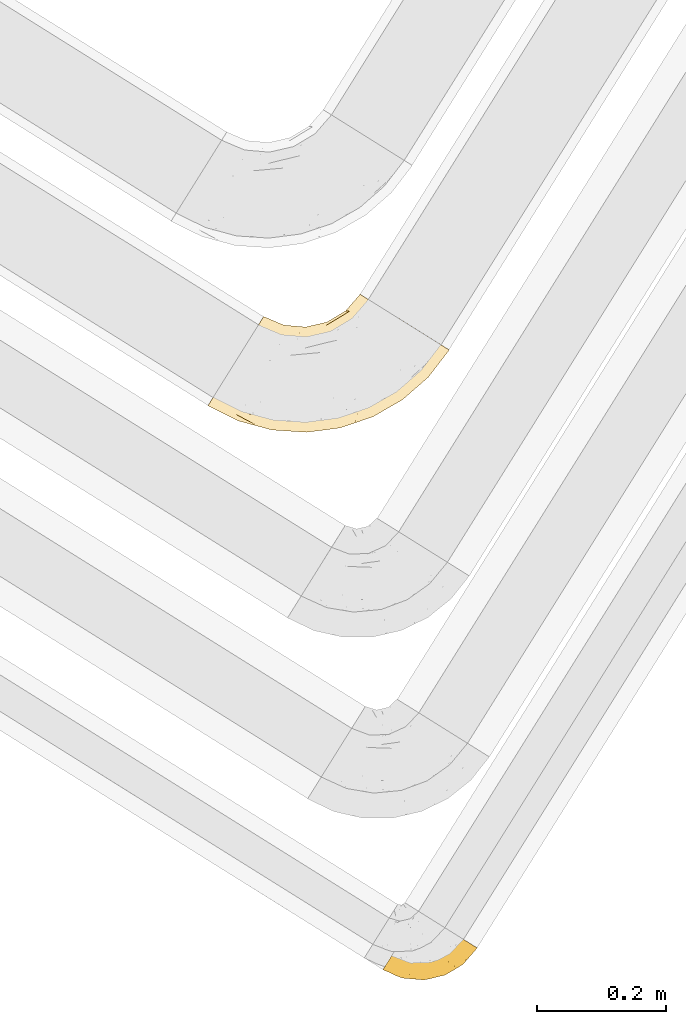
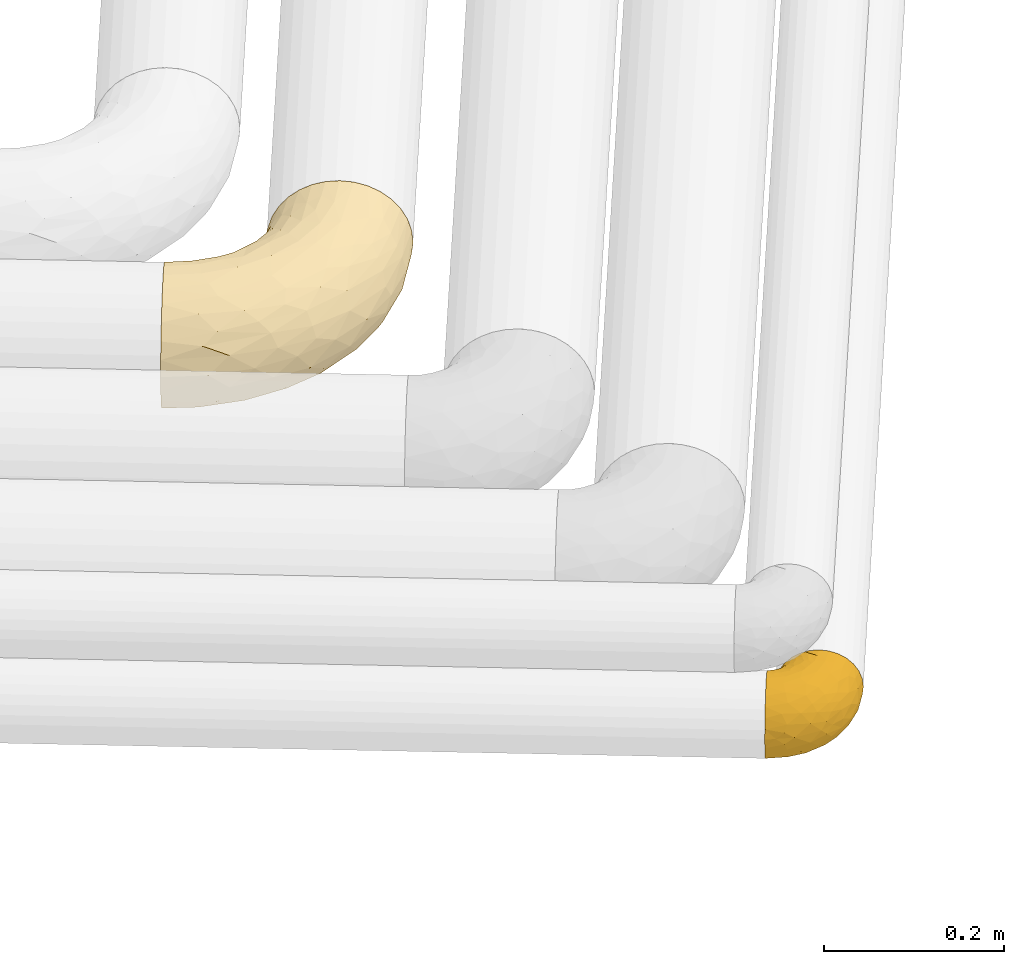
# One storey, part 21 of 93: 2 coverings.
"""IFC2X3 building model written with IfcOpenShell, lengths in millimetres."""

import ifcopenshell
import ifcopenshell.guid

model = None  # the IFC model being written
_history = None  # IfcOwnerHistory: only IFC2X3 demands one
_inside = {}  # id of a spatial element -> (the spatial element, [elements in it])
_under = {}  # id of a project, library or spatial element -> (it, [spatial elements below it])
_declared = {}  # id of a project -> (the project, [libraries it declares])
_typed = {}  # id of a type object -> (the type object, [elements of that type])
_made_of = {}  # id of a material, layer set ... -> (it, [elements and type objects made of it])


def new_model(schema):
    """Start an empty IFC model of exactly this schema.

    Asked for "IFC4X3", IfcOpenShell would pick the latest addendum, in which some entities
    have other attributes; the version numbers below select the first issue.
    IFC2X3 requires an IfcOwnerHistory on every rooted entity: one is made here for all.
    """
    global model, _history
    if schema == "IFC4X3":
        model = ifcopenshell.file(schema_version=(4, 3, 0, 0))
    else:
        model = ifcopenshell.file(schema=schema)
    _inside.clear()
    _under.clear()
    _declared.clear()
    _typed.clear()
    _made_of.clear()
    _history = None
    if model.schema == "IFC2X3":
        org = make("IfcOrganization", Name="unknown")
        user = make(
            "IfcPersonAndOrganization",
            ThePerson=make("IfcPerson", FamilyName="unknown"),
            TheOrganization=org,
        )
        app = make(
            "IfcApplication",
            ApplicationDeveloper=org,
            Version="unknown",
            ApplicationFullName="unknown",
            ApplicationIdentifier="unknown",
        )
        _history = make(
            "IfcOwnerHistory",
            OwningUser=user,
            OwningApplication=app,
            ChangeAction="ADDED",
            CreationDate=0,
        )
    return model


def make(cls, **values):
    """One entity of the class cls with the attributes given. An attribute that is None is left unset."""
    return model.create_entity(
        cls, **{name: value for name, value in values.items() if value is not None}
    )


def entity(cls, *values):
    """Any entity or typed value of the class cls, its attributes in the order of the schema. None: left unset."""
    e = model.create_entity(cls)
    for i, value in enumerate(values):
        if value is not None:
            e[i] = value
    return e


def rooted(cls, **values):
    """An entity with a GlobalId (a new one), such as an element, a storey or a relation."""
    return make(cls, GlobalId=ifcopenshell.guid.new(), OwnerHistory=_history, **values)


def si_unit(unit_type, name, prefix=None):
    """IfcSIUnit, for example si_unit("LENGTHUNIT", "METRE", prefix="MILLI")."""
    return make("IfcSIUnit", UnitType=unit_type, Prefix=prefix, Name=name)


def converted_unit(unit_type, name, factor, base, dimensions=None, offset=None):
    """IfcConversionBasedUnit, such as the inch: factor (a typed value) times the base unit."""
    return make(
        "IfcConversionBasedUnit"
        if offset is None
        else "IfcConversionBasedUnitWithOffset",
        ConversionOffset=offset,
        Dimensions=None
        if dimensions is None
        else entity("IfcDimensionalExponents", *dimensions),
        UnitType=unit_type,
        Name=name,
        ConversionFactor=make(
            "IfcMeasureWithUnit", ValueComponent=factor, UnitComponent=base
        ),
    )


def derived_unit(unit_type, elements):
    """IfcDerivedUnit: a product of units, each with its exponent."""
    return make(
        "IfcDerivedUnit",
        Elements=[
            make("IfcDerivedUnitElement", Unit=unit, Exponent=power)
            for unit, power in elements
        ],
        UnitType=unit_type,
    )


def assignment(units):
    """IfcUnitAssignment: the units of a project."""
    return None if units is None else make("IfcUnitAssignment", Units=units)


def point(xyz):
    """IfcCartesianPoint."""
    return None if xyz is None else make("IfcCartesianPoint", Coordinates=xyz)


def direction(xyz):
    """IfcDirection."""
    return None if xyz is None else make("IfcDirection", DirectionRatios=xyz)


def frame(location, z_axis=None, x_axis=None):
    """IfcAxis2Placement3D, a coordinate frame: its origin and axes. An axis left out is left unset."""
    return make(
        "IfcAxis2Placement3D",
        Location=point(location),
        Axis=direction(z_axis),
        RefDirection=direction(x_axis),
    )


def origin():
    """The frame at (0, 0, 0) with its axes left unset."""
    return frame((0.0, 0.0, 0.0))


def place(relative_to, where):
    """IfcLocalPlacement: puts the frame where relative to a parent placement (None: the world)."""
    return make(
        "IfcLocalPlacement", PlacementRelTo=relative_to, RelativePlacement=where
    )


def context(
    kind, dimensions, precision=None, world=None, true_north=None, identifier=None
):
    """IfcGeometricRepresentationContext, for example the 3D "Model" context."""
    return make(
        "IfcGeometricRepresentationContext",
        ContextIdentifier=identifier,
        ContextType=kind,
        CoordinateSpaceDimension=dimensions,
        Precision=precision,
        WorldCoordinateSystem=world,
        TrueNorth=true_north,
    )


def subcontext(parent, identifier, kind, view, scale=None):
    """IfcGeometricRepresentationSubContext, for example "Body" below "Model"."""
    return make(
        "IfcGeometricRepresentationSubContext",
        ContextIdentifier=identifier,
        ContextType=kind,
        ParentContext=parent,
        TargetScale=scale,
        TargetView=view,
    )


def project(units=None, contexts=None):
    """IfcProject with its units and contexts."""
    return rooted(
        "IfcProject",
        Name="project",
        RepresentationContexts=contexts,
        UnitsInContext=assignment(units),
    )


def spatial(cls, under=None, at=None, **own):
    """A site, building, storey or space (cls), placed at a placement, below another one or the project."""
    s = rooted(cls, ObjectPlacement=at, **own)
    if under is not None:
        _under.setdefault(under.id(), (under, []))[1].append(s)
    return s


def faces_of(points, faces, orient=None, outer=None):
    """IfcFace entities. A face is a list of loops; a loop is a list of indices into points, from 0.

    orient and outer hold one flag for each loop. By default every Orientation is true, the
    first loop of a face is its IfcFaceOuterBound and the others are IfcFaceBound.
    """
    made = []
    for i, loops in enumerate(faces):
        bounds = []
        for j, loop in enumerate(loops):
            is_outer = j == 0 if outer is None else outer[i][j]
            bounds.append(
                make(
                    "IfcFaceOuterBound" if is_outer else "IfcFaceBound",
                    Bound=make("IfcPolyLoop", Polygon=[points[k] for k in loop]),
                    Orientation=True if orient is None else orient[i][j],
                )
            )
        made.append(make("IfcFace", Bounds=bounds))
    return made


def faceted_brep(points, faces, orient=None, outer=None, voids=None):
    """IfcFacetedBrep: a solid bounded by flat faces; with voids (closed shells), ...WithVoids."""
    shared = [point(p) for p in points]
    hull = make("IfcClosedShell", CfsFaces=faces_of(shared, faces, orient, outer))
    if voids is None:
        return make("IfcFacetedBrep", Outer=hull)
    return make(
        "IfcFacetedBrepWithVoids",
        Outer=hull,
        Voids=[
            make(cls, CfsFaces=faces_of(shared, fs, o, b)) for cls, fs, o, b in voids
        ],
    )


def shape(context_of_items, identifier, shape_type, items):
    """IfcShapeRepresentation: the items that make up one representation, for example the "Body"."""
    return make(
        "IfcShapeRepresentation",
        ContextOfItems=context_of_items,
        RepresentationIdentifier=identifier,
        RepresentationType=shape_type,
        Items=items,
    )


def made_of(thing, what):
    """Note that an element or type object is made of a material, layer set ...; save() writes the relation."""
    if what is not None:
        _made_of.setdefault(what.id(), (what, []))[1].append(thing)
    return thing


def element(
    cls,
    number,
    at=None,
    inside=None,
    cuts=None,
    type_object=None,
    material=None,
    context=None,
    identifier="Body",
    shape_type=None,
    held_by="IfcProductDefinitionShape",
    body=None,
    shapes=None,
    **own,
):
    """One element of the class cls, such as IfcWall. Its Tag is "e" and its number.

    at: its placement. inside: the storey or other place that contains it. cuts: it is an
    opening in that element (IfcRelVoidsElement). A single representation is given by context,
    identifier, shape_type and body (its items); several are given by shapes. held_by: the class
    of the entity that holds the representations. save() writes the other relations.
    """
    e = rooted(cls, Tag="e%d" % number, ObjectPlacement=at, **own)
    if body is not None:
        shapes = [shape(context, identifier, shape_type, body)]
    if shapes is not None:
        e.Representation = make(held_by, Representations=shapes)
    if inside is not None:
        _inside.setdefault(inside.id(), (inside, []))[1].append(e)
    if cuts is not None:
        rooted(
            "IfcRelVoidsElement", RelatingBuildingElement=cuts, RelatedOpeningElement=e
        )
    if type_object is not None:
        _typed.setdefault(type_object.id(), (type_object, []))[1].append(e)
    return made_of(e, material)


def aggregate(whole, parts):
    """IfcRelAggregates: a whole, such as a stair, and the parts it consists of."""
    return rooted("IfcRelAggregates", RelatingObject=whole, RelatedObjects=parts)


def save(model, path):
    """Write the relations noted so far, then the file.

    IfcRelAggregates (storeys below a building ...), IfcRelContainedInSpatialStructure (elements
    in a storey), IfcRelDefinesByType, IfcRelAssociatesMaterial and IfcRelDeclares: one each for
    every whole, place, type object, material and project.
    """
    for whole, parts in _under.values():
        aggregate(whole, parts)
    for where, things in _inside.values():
        rooted(
            "IfcRelContainedInSpatialStructure",
            RelatedElements=things,
            RelatingStructure=where,
        )
    for kind, things in _typed.values():
        rooted("IfcRelDefinesByType", RelatedObjects=things, RelatingType=kind)
    for what, things in _made_of.values():
        rooted("IfcRelAssociatesMaterial", RelatedObjects=things, RelatingMaterial=what)
    for by, libraries in _declared.values():
        rooted("IfcRelDeclares", RelatingContext=by, RelatedDefinitions=libraries)
    model.write(path)


model = new_model("IFC2X3")

# Units and contexts
model_context = context("Model", 3, precision=0.01, world=origin(), true_north=direction((6.12303176911189e-17, 1.0)))
body_context = subcontext(model_context, "Body", "Model", "MODEL_VIEW")
ifc_project = project(units=[si_unit("LENGTHUNIT", "METRE", prefix="MILLI"), si_unit("AREAUNIT", "SQUARE_METRE"), si_unit("VOLUMEUNIT", "CUBIC_METRE"), converted_unit("PLANEANGLEUNIT", "DEGREE", entity("IfcRatioMeasure", 0.0174532925199433), si_unit("PLANEANGLEUNIT", "RADIAN"), dimensions=[0, 0, 0, 0, 0, 0, 0]), si_unit("MASSUNIT", "GRAM", prefix="KILO"), derived_unit("MASSDENSITYUNIT", [(si_unit("MASSUNIT", "GRAM", prefix="KILO"), 1), (si_unit("LENGTHUNIT", "METRE"), -3)]), derived_unit("MOMENTOFINERTIAUNIT", [(si_unit("LENGTHUNIT", "METRE"), 4)]), si_unit("TIMEUNIT", "SECOND"), si_unit("FREQUENCYUNIT", "HERTZ"), si_unit("THERMODYNAMICTEMPERATUREUNIT", "DEGREE_CELSIUS"), derived_unit("THERMALTRANSMITTANCEUNIT", [(si_unit("MASSUNIT", "GRAM", prefix="KILO"), 1), (si_unit("THERMODYNAMICTEMPERATUREUNIT", "KELVIN"), -1), (si_unit("TIMEUNIT", "SECOND"), -3)]), derived_unit("VOLUMETRICFLOWRATEUNIT", [(si_unit("LENGTHUNIT", "METRE"), 3), (si_unit("TIMEUNIT", "SECOND"), -1)]), derived_unit("MASSFLOWRATEUNIT", [(si_unit("MASSUNIT", "GRAM", prefix="KILO"), 1), (si_unit("TIMEUNIT", "SECOND"), -1)]), derived_unit("ROTATIONALFREQUENCYUNIT", [(si_unit("TIMEUNIT", "SECOND"), -1)]), si_unit("ELECTRICCURRENTUNIT", "AMPERE"), si_unit("ELECTRICVOLTAGEUNIT", "VOLT"), si_unit("POWERUNIT", "WATT"), si_unit("FORCEUNIT", "NEWTON", prefix="KILO"), si_unit("ILLUMINANCEUNIT", "LUX"), si_unit("LUMINOUSFLUXUNIT", "LUMEN"), si_unit("LUMINOUSINTENSITYUNIT", "CANDELA"), derived_unit("USERDEFINED", [(si_unit("MASSUNIT", "GRAM", prefix="KILO"), -1), (si_unit("LENGTHUNIT", "METRE"), -2), (si_unit("TIMEUNIT", "SECOND"), 3), (si_unit("LUMINOUSFLUXUNIT", "LUMEN"), 1)]), derived_unit("LINEARVELOCITYUNIT", [(si_unit("LENGTHUNIT", "METRE"), 1), (si_unit("TIMEUNIT", "SECOND"), -1)]), si_unit("PRESSUREUNIT", "PASCAL"), derived_unit("USERDEFINED", [(si_unit("LENGTHUNIT", "METRE"), -2), (si_unit("MASSUNIT", "GRAM", prefix="KILO"), 1), (si_unit("TIMEUNIT", "SECOND"), -2)]), derived_unit("LINEARFORCEUNIT", [(si_unit("MASSUNIT", "GRAM", prefix="KILO"), 1), (si_unit("LENGTHUNIT", "METRE"), 1), (si_unit("TIMEUNIT", "SECOND"), -2), (si_unit("LENGTHUNIT", "METRE"), -1)]), derived_unit("PLANARFORCEUNIT", [(si_unit("MASSUNIT", "GRAM", prefix="KILO"), 1), (si_unit("LENGTHUNIT", "METRE"), 1), (si_unit("TIMEUNIT", "SECOND"), -2), (si_unit("LENGTHUNIT", "METRE"), -2)])], contexts=[model_context])

# Site, building, storey
site_placement = place(None, origin())
site = spatial("IfcSite", under=ifc_project, at=site_placement, CompositionType="ELEMENT")
building_placement = place(site_placement, origin())
building = spatial("IfcBuilding", under=site, at=building_placement, CompositionType="ELEMENT")
storey_placement = place(building_placement, frame((0.0, 0.0, -4200.0)))
storey = spatial("IfcBuildingStorey", under=building, at=storey_placement, CompositionType="ELEMENT", Elevation=-4200.0)

# Coverings
covering_1_placement = place(storey_placement, frame((13072.91, 7155.01, 2916.9)))
element("IfcCovering", 1, at=covering_1_placement, inside=storey, Name=":ADSK_", ObjectType=":ADSK_", PredefinedType="INSULATION", context=body_context, shape_type="Brep", body=[
    faceted_brep([(333.05, 155.76, 158.39), (345.0, 148.29, 150.86), (355.47, 141.74, 140.72), (364.07, 136.37, 128.37), (370.45, 132.38, 114.28), (374.39, 129.93, 98.99), (375.71, 129.1, 83.1), (374.39, 129.93, 67.2), (370.45, 132.38, 51.91), (364.07, 136.37, 37.82), (355.47, 141.75, 25.47), (345.0, 148.29, 15.33), (333.05, 155.76, 7.8), (320.08, 163.86, 3.16), (306.6, 172.28, 1.6), (293.11, 180.71, 3.16), (280.15, 188.81, 7.8), (268.2, 196.28, 15.33), (257.72, 202.82, 25.47), (249.13, 208.19, 37.82), (242.74, 212.19, 51.91), (238.81, 214.64, 67.2), (237.48, 215.47, 83.1), (238.81, 214.64, 99.0), (242.74, 212.18, 114.28), (249.13, 208.19, 128.37), (257.73, 202.82, 140.72), (268.2, 196.28, 150.86), (280.15, 188.81, 158.39), (293.11, 180.71, 163.03), (306.6, 172.28, 164.6), (320.08, 163.86, 163.03), (86.5, 178.6, 62.0), (82.19, 171.7, 42.35), (75.32, 160.71, 25.47), (66.38, 146.4, 12.51), (55.96, 129.73, 4.37), (44.78, 111.84, 1.6), (33.61, 93.95, 4.37), (23.19, 77.28, 12.51), (14.24, 62.97, 25.47), (7.38, 51.98, 42.35), (3.07, 45.08, 62.0), (1.6, 42.72, 83.1), (3.07, 45.08, 104.19), (7.38, 51.98, 123.85), (14.24, 62.97, 140.72), (23.19, 77.28, 153.68), (33.61, 93.95, 161.82), (44.78, 111.84, 164.6), (55.96, 129.73, 161.82), (66.38, 146.4, 153.68), (75.32, 160.71, 140.72), (82.19, 171.7, 123.85), (86.5, 178.6, 104.19), (87.97, 180.96, 83.1), (73.32, 14.25, 104.67), (49.28, 19.08, 83.1), (100.66, 5.19, 83.1), (114.71, 20.18, 132.71), (174.6, 16.99, 128.57), (151.43, 25.0, 140.31), (233.45, 29.73, 127.0), (177.21, 8.64, 111.93), (231.49, 19.35, 107.33), (179.96, 4.78, 96.47), (307.55, 107.43, 153.13), (124.77, 10.77, 119.3), (130.28, 3.96, 101.32), (248.47, 50.29, 142.92), (292.17, 75.9, 142.61), (267.0, 73.32, 151.87), (82.36, 74.66, 162.56), (124.67, 84.11, 164.6), (83.16, 93.47, 164.6), (153.76, 1.6, 83.1), (294.51, 55.47, 117.97), (330.51, 86.29, 119.64), (292.72, 63.77, 131.15), (206.54, 8.43, 83.1), (256.98, 25.43, 83.1), (83.34, 56.33, 156.52), (103.14, 32.76, 144.21), (53.94, 49.47, 146.25), (66.06, 29.24, 130.43), (280.15, 138.95, 164.6), (268.66, 104.99, 162.51), (152.45, 56.01, 159.97), (160.3, 38.77, 151.26), (218.74, 49.94, 151.21), (47.82, 27.91, 117.68), (235.35, 70.49, 158.25), (225.16, 83.18, 163.04), (334.96, 82.83, 105.24), (293.47, 47.68, 100.78), (326.56, 110.08, 144.52), (200.91, 32.82, 141.87), (327.62, 95.07, 132.77), (303.13, 51.94, 83.1), (343.22, 86.94, 83.1), (246.96, 112.34, 164.6), (208.67, 93.79, 164.6), (167.21, 84.22, 164.6), (96.56, 136.17, 151.23), (115.61, 146.97, 137.69), (92.84, 114.26, 161.34), (212.5, 158.19, 141.27), (235.38, 178.47, 138.72), (213.32, 172.34, 127.05), (183.93, 166.75, 109.71), (215.21, 189.85, 83.1), (186.11, 172.37, 83.1), (141.85, 155.47, 120.43), (152.86, 142.71, 138.75), (180.6, 155.3, 129.2), (208.22, 115.77, 161.91), (232.67, 129.94, 161.43), (208.21, 132.86, 155.97), (141.4, 101.07, 162.57), (182.16, 114.05, 160.03), (161.3, 127.64, 151.82), (109.57, 162.72, 117.14), (221.04, 189.1, 109.48), (251.07, 178.12, 148.92), (233.51, 156.04, 151.93), (129.93, 122.41, 154.85), (109.87, 168.83, 98.92), (136.86, 162.82, 100.98), (153.04, 164.73, 83.1), (119.22, 167.69, 83.1), (187.72, 142.04, 145.5), (257.98, 161.65, 158.16), (255.6, 138.49, 162.97), (275.48, 159.5, 162.71), (163.68, 164.47, 98.76), (117.12, 112.0, 160.15), (232.57, 191.04, 124.12), (185.16, 128.4, 154.06), (129.93, 122.41, 11.34), (115.61, 146.97, 28.5), (152.86, 142.71, 27.44), (161.3, 127.64, 14.37), (109.87, 168.83, 67.27), (136.86, 162.82, 65.22), (213.32, 172.34, 39.14), (212.5, 158.19, 24.93), (180.59, 155.3, 36.99), (275.48, 159.5, 3.48), (183.93, 166.75, 56.48), (96.56, 136.17, 14.96), (92.84, 114.26, 4.85), (232.57, 191.04, 42.07), (235.37, 178.47, 27.47), (141.85, 155.47, 45.76), (163.68, 164.47, 67.43), (255.6, 138.49, 3.22), (257.97, 161.65, 8.03), (83.16, 93.47, 1.6), (109.57, 162.72, 49.05), (251.06, 178.12, 17.27), (221.04, 189.1, 56.71), (116.64, 100.86, 3.08), (141.4, 101.07, 3.62), (246.96, 112.34, 1.6), (208.67, 93.79, 1.6), (232.67, 129.94, 4.76), (167.21, 84.22, 1.6), (124.67, 84.11, 1.6), (187.72, 142.04, 20.69), (182.16, 114.05, 6.16), (233.51, 156.04, 14.26), (208.21, 132.86, 10.22), (208.22, 115.77, 4.28), (280.15, 138.95, 1.6), (185.27, 128.83, 12.35), (66.06, 29.24, 35.76), (292.17, 75.9, 23.58), (292.75, 63.8, 35.03), (252.21, 41.3, 34.03), (341.92, 98.49, 46.35), (108.38, 67.99, 3.68), (157.04, 67.45, 3.15), (153.44, 51.58, 7.94), (200.91, 32.82, 24.32), (196.81, 18.01, 41.48), (234.3, 74.91, 6.22), (267.73, 108.91, 2.91), (173.65, 7.09, 57.48), (95.34, 51.66, 10.43), (109.73, 21.2, 33.0), (103.14, 32.76, 21.98), (150.87, 22.88, 28.1), (80.4, 17.62, 47.91), (326.56, 110.08, 21.67), (231.49, 19.35, 58.86), (300.52, 98.91, 13.93), (124.77, 10.77, 46.89), (124.71, 4.81, 62.93), (53.94, 49.47, 19.94), (73.32, 14.25, 61.52), (250.33, 62.77, 15.08), (289.86, 109.21, 6.68), (293.47, 47.68, 65.41), (158.95, 36.16, 16.65), (202.31, 51.14, 11.53), (334.96, 82.83, 60.95), (327.61, 95.07, 33.42), (294.51, 55.47, 48.22)], [[[0, 1, 2, 3, 4, 5, 6, 7, 8, 9, 10, 11, 12, 13, 14, 15, 16, 17, 18, 19, 20, 21, 22, 23, 24, 25, 26, 27, 28, 29, 30, 31]], [[32, 33, 34, 35, 36, 37, 38, 39, 40, 41, 42, 43, 44, 45, 46, 47, 48, 49, 50, 51, 52, 53, 54, 55]], [[56, 57, 58]], [[57, 44, 43]], [[59, 60, 61]], [[62, 63, 64]], [[63, 65, 64]], [[1, 0, 66]], [[67, 68, 63]], [[69, 70, 71]], [[72, 73, 74]], [[75, 68, 58]], [[76, 77, 78]], [[64, 79, 80]], [[81, 48, 47]], [[82, 83, 84]], [[31, 85, 86]], [[71, 70, 66]], [[47, 83, 81]], [[87, 88, 89]], [[69, 62, 78]], [[49, 48, 72]], [[90, 44, 56]], [[48, 81, 72]], [[87, 91, 92]], [[93, 76, 94]], [[70, 95, 66]], [[88, 96, 89]], [[45, 84, 46]], [[2, 95, 97]], [[4, 93, 5]], [[98, 99, 93]], [[59, 84, 67]], [[3, 97, 77]], [[71, 86, 91]], [[4, 3, 77]], [[90, 84, 45]], [[99, 6, 5]], [[83, 47, 46]], [[95, 2, 1]], [[94, 80, 98]], [[100, 101, 92]], [[66, 31, 86]], [[60, 63, 62]], [[85, 31, 30]], [[102, 87, 92]], [[93, 77, 76]], [[91, 86, 92]], [[44, 57, 56]], [[86, 85, 100]], [[78, 97, 70]], [[87, 102, 73]], [[2, 97, 3]], [[67, 84, 90]], [[31, 66, 0]], [[93, 94, 98]], [[88, 81, 82]], [[99, 5, 93]], [[87, 73, 72]], [[66, 95, 1]], [[97, 95, 70]], [[86, 71, 66]], [[69, 89, 96]], [[89, 71, 91]], [[69, 96, 62]], [[60, 62, 96]], [[76, 62, 64]], [[71, 89, 69]], [[87, 89, 91]], [[81, 88, 87]], [[61, 88, 82]], [[61, 60, 96]], [[60, 67, 63]], [[68, 67, 56]], [[79, 65, 75]], [[58, 68, 56]], [[65, 68, 75]], [[64, 65, 79]], [[68, 65, 63]], [[76, 64, 94]], [[80, 94, 64]], [[100, 92, 86]], [[92, 101, 102]], [[88, 61, 96]], [[59, 61, 82]], [[84, 59, 82]], [[60, 59, 67]], [[87, 72, 81]], [[49, 72, 74]], [[84, 83, 46]], [[81, 83, 82]], [[69, 78, 70]], [[62, 76, 78]], [[4, 77, 93]], [[78, 77, 97]], [[44, 90, 45]], [[67, 90, 56]], [[103, 104, 52]], [[50, 49, 74]], [[50, 74, 105]], [[106, 107, 108]], [[109, 110, 111]], [[112, 113, 114]], [[104, 113, 112]], [[73, 105, 74]], [[115, 116, 117]], [[118, 119, 120]], [[104, 53, 52]], [[51, 103, 52]], [[53, 121, 54]], [[24, 23, 122]], [[123, 107, 124]], [[122, 109, 108]], [[125, 120, 113]], [[55, 54, 126]], [[102, 118, 73]], [[127, 126, 121]], [[128, 129, 127]], [[105, 51, 50]], [[102, 101, 119]], [[120, 130, 113]], [[26, 123, 27]], [[27, 131, 28]], [[132, 85, 133]], [[85, 29, 133]], [[134, 111, 128]], [[28, 133, 29]], [[30, 29, 85]], [[116, 131, 124]], [[135, 73, 118]], [[27, 123, 131]], [[110, 23, 22]], [[136, 122, 108]], [[24, 136, 25]], [[114, 108, 109]], [[119, 115, 117]], [[136, 107, 25]], [[128, 127, 134]], [[122, 110, 109]], [[104, 112, 121]], [[107, 106, 124]], [[107, 26, 25]], [[23, 110, 122]], [[101, 100, 116]], [[131, 132, 133]], [[105, 135, 103]], [[116, 124, 117]], [[122, 136, 24]], [[107, 136, 108]], [[28, 131, 133]], [[131, 116, 132]], [[126, 127, 129]], [[134, 112, 109]], [[107, 123, 26]], [[131, 123, 124]], [[104, 121, 53]], [[127, 121, 112]], [[105, 103, 51]], [[104, 103, 125]], [[116, 100, 132]], [[85, 132, 100]], [[106, 117, 124]], [[137, 130, 120]], [[114, 106, 108]], [[106, 130, 117]], [[119, 118, 102]], [[135, 118, 125]], [[125, 113, 104]], [[114, 113, 130]], [[114, 130, 106]], [[112, 114, 109]], [[118, 120, 125]], [[117, 137, 119]], [[55, 126, 129]], [[121, 126, 54]], [[112, 134, 127]], [[111, 134, 109]], [[119, 101, 115]], [[101, 116, 115]], [[103, 135, 125]], [[73, 135, 105]], [[130, 137, 117]], [[120, 119, 137]], [[138, 139, 140]], [[140, 141, 138]], [[55, 129, 142]], [[143, 142, 129]], [[144, 145, 146]], [[147, 16, 15]], [[110, 148, 111]], [[128, 143, 129]], [[149, 150, 35]], [[151, 152, 144]], [[153, 143, 154]], [[147, 155, 156]], [[35, 150, 36]], [[37, 36, 157]], [[35, 34, 149]], [[139, 33, 158]], [[159, 152, 18]], [[150, 157, 36]], [[140, 139, 153]], [[139, 34, 33]], [[110, 21, 160]], [[150, 161, 157]], [[20, 19, 151]], [[161, 138, 162]], [[110, 22, 21]], [[163, 164, 165]], [[166, 167, 162]], [[151, 160, 20]], [[140, 146, 168]], [[111, 148, 154]], [[164, 166, 169]], [[18, 152, 19]], [[170, 156, 165]], [[17, 159, 18]], [[158, 33, 32]], [[171, 165, 172]], [[155, 165, 156]], [[148, 110, 160]], [[170, 159, 156]], [[160, 144, 148]], [[15, 14, 173]], [[170, 171, 145]], [[149, 139, 138]], [[15, 173, 147]], [[144, 152, 145]], [[156, 17, 16]], [[165, 171, 170]], [[20, 160, 21]], [[171, 172, 169]], [[169, 166, 162]], [[152, 151, 19]], [[160, 151, 144]], [[155, 173, 163]], [[156, 16, 147]], [[154, 143, 128]], [[143, 153, 158]], [[156, 159, 17]], [[152, 159, 170]], [[158, 32, 142]], [[139, 158, 153]], [[139, 149, 34]], [[150, 149, 138]], [[173, 155, 147]], [[163, 165, 155]], [[174, 169, 141]], [[145, 171, 168]], [[170, 145, 152]], [[146, 145, 168]], [[161, 162, 167]], [[162, 138, 141]], [[146, 153, 148]], [[140, 168, 141]], [[153, 146, 140]], [[144, 146, 148]], [[174, 141, 168]], [[162, 141, 169]], [[158, 142, 143]], [[55, 142, 32]], [[111, 154, 128]], [[153, 154, 148]], [[165, 164, 172]], [[164, 169, 172]], [[157, 161, 167]], [[138, 161, 150]], [[168, 171, 174]], [[169, 174, 171]], [[41, 40, 175]], [[176, 177, 178]], [[9, 8, 179]], [[180, 181, 182]], [[157, 180, 37]], [[183, 178, 184]], [[164, 185, 181]], [[13, 186, 173]], [[187, 79, 75]], [[167, 166, 181]], [[186, 163, 173]], [[182, 188, 180]], [[57, 43, 42]], [[189, 190, 191]], [[164, 186, 185]], [[192, 41, 175]], [[193, 11, 10]], [[178, 194, 184]], [[12, 11, 195]], [[196, 187, 197]], [[40, 198, 175]], [[198, 40, 39]], [[58, 199, 197]], [[200, 185, 201]], [[163, 186, 164]], [[201, 185, 186]], [[202, 80, 194]], [[190, 203, 191]], [[201, 186, 13]], [[204, 185, 200]], [[201, 13, 12]], [[41, 199, 42]], [[195, 200, 201]], [[98, 205, 99]], [[57, 42, 199]], [[13, 173, 14]], [[58, 57, 199]], [[193, 206, 176]], [[80, 79, 194]], [[207, 205, 202]], [[196, 184, 187]], [[202, 205, 98]], [[205, 179, 8]], [[9, 206, 10]], [[207, 206, 179]], [[182, 203, 188]], [[6, 99, 7]], [[188, 38, 180]], [[203, 182, 204]], [[7, 205, 8]], [[37, 180, 38]], [[167, 180, 157]], [[7, 99, 205]], [[182, 181, 185]], [[11, 193, 195]], [[196, 191, 184]], [[175, 189, 192]], [[198, 188, 190]], [[38, 188, 39]], [[206, 193, 10]], [[195, 193, 176]], [[195, 176, 200]], [[12, 195, 201]], [[178, 200, 176]], [[185, 204, 182]], [[200, 183, 204]], [[203, 204, 183]], [[191, 203, 183]], [[188, 203, 190]], [[184, 191, 183]], [[190, 189, 175]], [[200, 178, 183]], [[184, 194, 187]], [[177, 176, 206]], [[194, 178, 207]], [[79, 187, 194]], [[197, 199, 192]], [[187, 75, 197]], [[58, 197, 75]], [[191, 196, 189]], [[192, 189, 196]], [[80, 202, 98]], [[194, 207, 202]], [[167, 181, 180]], [[181, 166, 164]], [[188, 198, 39]], [[175, 198, 190]], [[207, 179, 205]], [[9, 179, 206]], [[197, 192, 196]], [[41, 192, 199]], [[206, 207, 177]], [[207, 178, 177]]]),
])
covering_2_placement = place(storey_placement, frame((13344.15, 6306.06, 2892.1)))
element("IfcCovering", 2, at=covering_2_placement, inside=storey, Name=":ADSK_", ObjectType=":ADSK_", PredefinedType="INSULATION", context=body_context, shape_type="Brep", body=[
    faceted_brep([(106.18, 77.28, 99.9), (115.46, 71.48, 98.66), (124.28, 65.98, 95.02), (132.18, 61.04, 89.17), (138.78, 56.92, 81.38), (143.74, 53.81, 72.06), (146.82, 51.89, 61.68), (147.87, 51.24, 50.75), (146.82, 51.89, 39.8), (143.74, 53.82, 29.41), (138.77, 56.92, 20.09), (132.17, 61.05, 12.31), (124.26, 65.98, 6.46), (115.45, 71.49, 2.83), (106.18, 77.28, 1.6), (101.35, 80.3, 2.24), (96.91, 83.08, 2.83), (92.5, 85.83, 4.65), (88.09, 88.59, 6.47), (80.19, 93.52, 12.32), (73.59, 97.65, 20.11), (68.63, 100.75, 29.43), (65.55, 102.67, 39.81), (64.5, 103.33, 50.75), (65.55, 102.67, 61.69), (68.63, 100.75, 72.08), (73.6, 97.64, 81.4), (80.2, 93.52, 89.18), (88.11, 88.58, 95.03), (92.51, 85.83, 96.85), (96.92, 83.07, 98.66), (101.35, 80.3, 99.25), (103.77, 78.79, 99.57), (52.8, 99.41, 38.02), (50.2, 95.25, 26.17), (48.13, 91.93, 21.08), (46.06, 88.62, 15.99), (43.36, 84.31, 12.09), (40.66, 79.99, 8.18), (37.52, 74.96, 5.73), (34.38, 69.94, 3.27), (30.68, 64.01, 2.35), (29.16, 61.58, 1.97), (27.64, 59.15, 1.6), (20.9, 48.36, 3.27), (14.62, 38.31, 8.18), (9.22, 29.67, 15.99), (5.08, 23.05, 26.17), (2.48, 18.89, 38.02), (1.6, 17.47, 50.75), (2.48, 18.89, 63.47), (5.08, 23.05, 75.32), (9.22, 29.67, 85.5), (14.62, 38.31, 93.31), (20.9, 48.36, 98.22), (27.64, 59.15, 99.9), (30.68, 64.01, 99.14), (34.38, 69.94, 98.22), (37.52, 74.96, 95.77), (40.66, 79.99, 93.31), (43.36, 84.31, 89.4), (46.06, 88.62, 85.5), (48.13, 91.93, 80.41), (50.2, 95.25, 75.32), (52.8, 99.41, 63.47), (53.69, 100.83, 50.75), (73.31, 3.23, 59.31), (63.34, 6.85, 73.08), (52.09, 3.24, 63.72), (32.17, 4.49, 50.75), (21.61, 8.39, 58.64), (12.86, 12.69, 50.75), (43.87, 9.77, 76.74), (25.69, 9.49, 67.68), (23.01, 16.67, 78.92), (98.3, 38.75, 94.31), (101.46, 55.97, 98.76), (83.87, 43.54, 98.4), (36.32, 31.21, 94.57), (56.63, 20.8, 89.91), (63.92, 32.34, 96.32), (40.28, 42.43, 98.79), (48.44, 51.27, 99.9), (43.21, 53.25, 99.9), (37.98, 55.23, 99.9), (35.39, 56.21, 99.9), (32.81, 57.19, 99.9), (33.49, 21.01, 87.31), (112.0, 52.64, 95.61), (112.46, 17.59, 60.43), (130.36, 32.99, 65.24), (112.5, 22.68, 72.87), (90.95, 61.08, 99.9), (85.88, 58.8, 99.9), (80.81, 56.51, 99.9), (75.74, 54.23, 99.9), (70.67, 51.95, 99.9), (118.64, 47.08, 90.65), (96.67, 10.4, 63.14), (74.9, 25.36, 91.89), (131.15, 40.05, 75.25), (139.84, 42.0, 50.75), (59.94, 12.73, 82.18), (78.9, 17.76, 85.08), (80.37, 11.5, 76.93), (97.61, 9.07, 50.75), (81.43, 5.33, 50.75), (121.38, 38.11, 83.02), (104.29, 75.27, 99.9), (102.4, 73.26, 99.9), (98.61, 69.23, 99.9), (94.78, 65.16, 99.9), (103.3, 29.76, 87.13), (95.69, 19.42, 80.85), (61.66, 42.17, 99.17), (126.08, 26.17, 50.75), (65.11, 51.78, 99.9), (59.55, 51.61, 99.9), (54.0, 51.44, 99.9), (65.25, 1.6, 50.75), (81.05, 6.96, 67.61), (96.0, 13.76, 72.25), (111.84, 17.62, 50.75), (48.71, 3.04, 50.75), (91.72, 76.09, 98.69), (38.92, 63.66, 99.01), (48.91, 61.7, 98.79), (43.4, 65.35, 98.29), (64.06, 98.2, 68.51), (66.59, 94.88, 76.82), (81.93, 68.86, 98.54), (86.96, 67.63, 99.3), (52.94, 87.67, 83.57), (50.78, 81.71, 89.47), (56.25, 92.88, 75.76), (58.26, 85.87, 84.86), (62.6, 93.51, 75.89), (58.48, 97.61, 64.77), (66.65, 80.31, 90.83), (71.97, 75.63, 94.62), (72.35, 83.63, 90.37), (47.07, 80.5, 91.18), (75.48, 88.78, 88.65), (69.69, 90.26, 84.11), (61.83, 77.85, 91.75), (85.19, 78.29, 96.86), (59.61, 99.84, 50.75), (62.39, 100.25, 58.97), (76.09, 66.51, 98.37), (65.46, 88.2, 83.91), (68.03, 66.83, 97.52), (48.73, 71.84, 95.55), (54.08, 61.15, 98.76), (54.18, 71.52, 95.26), (61.38, 64.0, 98.04), (56.26, 79.22, 90.65), (80.2, 83.52, 93.51), (76.45, 79.07, 94.16), (58.74, 59.29, 99.1), (56.24, 92.88, 25.73), (56.25, 79.23, 10.84), (52.93, 87.67, 17.92), (58.24, 85.89, 16.64), (65.43, 97.88, 30.44), (81.93, 68.85, 2.95), (86.96, 67.64, 2.19), (85.88, 58.8, 1.6), (85.18, 78.3, 4.63), (69.68, 90.26, 17.39), (30.22, 58.17, 1.6), (37.98, 55.23, 1.6), (32.81, 57.19, 1.6), (75.45, 88.78, 12.86), (72.33, 83.63, 11.13), (43.4, 65.35, 3.2), (48.73, 71.84, 5.94), (50.78, 81.7, 12.02), (54.18, 71.52, 6.23), (47.07, 80.5, 10.31), (80.17, 83.55, 8.0), (76.44, 79.08, 7.34), (38.92, 63.66, 2.48), (54.08, 61.15, 2.73), (48.97, 61.41, 2.64), (98.61, 69.23, 1.6), (91.71, 76.09, 2.8), (58.47, 97.61, 36.71), (43.21, 53.25, 1.6), (48.44, 51.27, 1.6), (62.49, 99.34, 38.59), (102.4, 73.26, 1.6), (100.51, 71.24, 1.6), (80.81, 56.51, 1.6), (76.09, 66.51, 3.12), (65.44, 88.21, 17.59), (75.74, 54.23, 1.6), (68.0, 66.86, 3.98), (71.96, 75.62, 6.87), (61.38, 64.01, 3.45), (61.81, 77.88, 9.76), (94.78, 65.16, 1.6), (90.95, 61.08, 1.6), (62.6, 93.51, 25.62), (66.64, 80.32, 10.67), (58.74, 59.29, 2.39), (59.55, 51.61, 1.6), (54.0, 51.44, 1.6), (65.11, 51.78, 1.6), (70.67, 51.95, 1.6), (61.75, 41.76, 2.4), (21.61, 8.39, 42.85), (33.49, 21.01, 14.18), (56.28, 20.84, 11.56), (59.9, 12.76, 19.27), (43.88, 9.76, 24.75), (63.39, 6.88, 28.37), (112.3, 52.74, 5.95), (101.55, 55.68, 2.79), (40.28, 42.43, 2.71), (52.09, 3.24, 37.78), (25.69, 9.49, 33.81), (23.02, 16.67, 22.57), (36.32, 31.21, 6.92), (112.5, 22.69, 28.61), (130.36, 32.99, 36.24), (112.45, 17.59, 41.05), (80.47, 11.53, 24.55), (81.05, 6.96, 33.88), (98.8, 39.2, 7.11), (73.31, 3.23, 42.18), (121.37, 38.11, 18.46), (118.63, 47.09, 10.84), (95.81, 19.43, 20.69), (96.03, 13.75, 29.27), (83.87, 43.5, 3.1), (81.13, 27.58, 9.18), (96.63, 10.38, 38.38), (131.14, 40.05, 26.23), (103.13, 29.68, 14.34), (64.07, 31.65, 5.46), (78.9, 17.77, 16.39)], [[[0, 1, 2, 3, 4, 5, 6, 7, 8, 9, 10, 11, 12, 13, 14, 15, 16, 17, 18, 19, 20, 21, 22, 23, 24, 25, 26, 27, 28, 29, 30, 31, 32]], [[33, 34, 35, 36, 37, 38, 39, 40, 41, 42, 43, 44, 45, 46, 47, 48, 49, 50, 51, 52, 53, 54, 55, 56, 57, 58, 59, 60, 61, 62, 63, 64, 65]], [[66, 67, 68]], [[69, 70, 71]], [[68, 72, 73]], [[73, 72, 74]], [[75, 76, 77]], [[78, 79, 80]], [[51, 50, 73]], [[81, 82, 83, 84, 85, 86, 55]], [[52, 87, 53]], [[74, 52, 51]], [[2, 1, 88]], [[89, 90, 91]], [[77, 92, 93, 94, 95, 96]], [[55, 54, 81]], [[78, 53, 87]], [[5, 90, 6]], [[88, 76, 75]], [[97, 3, 2]], [[89, 91, 98]], [[99, 80, 79]], [[90, 5, 100]], [[74, 87, 52]], [[100, 5, 4]], [[90, 101, 6]], [[79, 102, 103]], [[102, 67, 104]], [[105, 98, 106]], [[107, 4, 3]], [[76, 0, 108, 109, 110, 111, 92]], [[107, 112, 113]], [[114, 77, 96]], [[89, 115, 90]], [[114, 96, 116, 117, 118, 82]], [[75, 97, 88]], [[119, 66, 68]], [[50, 71, 70]], [[100, 91, 90]], [[99, 77, 80]], [[102, 104, 103]], [[97, 107, 3]], [[80, 81, 78]], [[107, 97, 112]], [[68, 73, 70]], [[66, 98, 120]], [[78, 81, 54]], [[114, 81, 80]], [[53, 78, 54]], [[78, 87, 79]], [[102, 87, 72]], [[79, 103, 99]], [[4, 107, 100]], [[91, 100, 107]], [[88, 97, 2]], [[112, 97, 75]], [[99, 112, 75]], [[103, 104, 113]], [[91, 121, 98]], [[89, 105, 122, 115]], [[101, 90, 115]], [[101, 7, 6]], [[88, 1, 76]], [[0, 76, 1]], [[92, 77, 76]], [[73, 74, 51]], [[87, 74, 72]], [[81, 114, 82]], [[77, 114, 80]], [[87, 102, 79]], [[67, 102, 72]], [[68, 67, 72]], [[67, 120, 104]], [[120, 121, 104]], [[104, 121, 113]], [[121, 120, 98]], [[91, 107, 113]], [[91, 113, 121]], [[103, 113, 112]], [[106, 98, 66]], [[105, 89, 98]], [[106, 66, 119]], [[67, 66, 120]], [[68, 69, 123, 119]], [[50, 49, 71]], [[50, 70, 73]], [[112, 99, 103]], [[77, 99, 75]], [[69, 68, 70]], [[29, 124, 110]], [[84, 83, 125]], [[126, 82, 118]], [[59, 58, 127]], [[25, 128, 129]], [[130, 93, 131]], [[132, 62, 133]], [[134, 135, 136]], [[137, 65, 64]], [[64, 134, 137]], [[138, 139, 140]], [[111, 110, 124, 92]], [[134, 136, 137]], [[134, 64, 63]], [[141, 61, 60]], [[125, 58, 57]], [[142, 143, 140]], [[142, 26, 143]], [[127, 83, 82]], [[28, 124, 29]], [[108, 0, 32, 31, 30, 110, 109]], [[30, 29, 110]], [[135, 144, 138]], [[28, 145, 124]], [[57, 56, 55, 86, 85, 84]], [[146, 147, 23]], [[24, 23, 147]], [[25, 143, 26]], [[95, 94, 148]], [[24, 128, 25]], [[149, 138, 143]], [[124, 145, 131]], [[127, 58, 125]], [[150, 148, 139]], [[127, 126, 151]], [[151, 59, 127]], [[152, 151, 126]], [[153, 154, 155]], [[153, 133, 141]], [[145, 28, 27]], [[142, 156, 27]], [[157, 148, 130]], [[61, 133, 62]], [[134, 132, 135]], [[147, 128, 24]], [[65, 137, 146]], [[146, 137, 147]], [[128, 137, 136]], [[137, 128, 147]], [[128, 136, 129]], [[149, 129, 136]], [[25, 129, 143]], [[158, 152, 117]], [[152, 118, 117]], [[153, 151, 152]], [[158, 116, 154]], [[144, 150, 138]], [[153, 152, 158]], [[133, 153, 155]], [[133, 155, 132]], [[141, 60, 151]], [[135, 132, 155]], [[134, 63, 132]], [[144, 135, 155]], [[135, 138, 149]], [[155, 154, 144]], [[150, 154, 96]], [[154, 150, 144]], [[148, 94, 130]], [[82, 126, 127]], [[118, 152, 126]], [[150, 96, 95]], [[139, 148, 157]], [[150, 95, 148]], [[93, 92, 131]], [[130, 145, 156]], [[130, 94, 93]], [[84, 125, 57]], [[127, 125, 83]], [[140, 139, 157]], [[150, 139, 138]], [[140, 157, 142]], [[138, 140, 143]], [[156, 142, 157]], [[27, 26, 142]], [[130, 156, 157]], [[145, 27, 156]], [[132, 63, 62]], [[124, 131, 92]], [[130, 131, 145]], [[129, 149, 143]], [[135, 149, 136]], [[153, 141, 151]], [[59, 151, 60]], [[133, 61, 141]], [[116, 96, 154]], [[153, 158, 154]], [[158, 117, 116]], [[34, 33, 159]], [[160, 161, 162]], [[22, 21, 163]], [[164, 165, 166]], [[19, 18, 167]], [[168, 21, 20]], [[169, 43, 42, 41, 40, 170, 171]], [[172, 173, 168]], [[174, 38, 175]], [[176, 177, 178]], [[179, 164, 180]], [[40, 181, 170]], [[182, 183, 175]], [[17, 184, 185]], [[65, 146, 186]], [[187, 174, 188]], [[23, 22, 189]], [[174, 39, 38]], [[15, 14, 190, 191, 184, 16]], [[181, 40, 39]], [[192, 193, 164]], [[194, 163, 168]], [[33, 186, 159]], [[180, 173, 172]], [[195, 196, 193]], [[18, 185, 167]], [[173, 180, 197]], [[198, 199, 196]], [[200, 201, 185, 184]], [[184, 17, 16]], [[18, 17, 185]], [[202, 159, 186]], [[194, 168, 203]], [[189, 163, 202]], [[204, 205, 182]], [[187, 181, 174]], [[160, 177, 176]], [[206, 183, 182]], [[206, 182, 205]], [[201, 165, 185]], [[165, 164, 167]], [[172, 179, 180]], [[202, 194, 162]], [[176, 161, 160]], [[65, 186, 33]], [[163, 189, 22]], [[175, 177, 182]], [[174, 183, 188]], [[177, 198, 204]], [[199, 160, 162]], [[198, 207, 204]], [[175, 38, 37]], [[198, 177, 160]], [[178, 177, 175]], [[176, 35, 161]], [[34, 159, 161]], [[162, 161, 159]], [[202, 162, 159]], [[199, 162, 203]], [[196, 199, 203]], [[198, 160, 199]], [[193, 197, 180]], [[208, 198, 196]], [[188, 183, 206]], [[175, 183, 174]], [[193, 192, 195]], [[195, 208, 196]], [[197, 196, 203]], [[180, 164, 193]], [[168, 163, 21]], [[166, 165, 201]], [[166, 192, 164]], [[189, 202, 186]], [[186, 146, 189]], [[23, 189, 146]], [[174, 181, 39]], [[170, 181, 187]], [[196, 197, 193]], [[173, 203, 168]], [[203, 173, 197]], [[172, 168, 20]], [[20, 19, 172]], [[179, 172, 19]], [[19, 167, 179]], [[164, 179, 167]], [[35, 176, 36]], [[35, 34, 161]], [[185, 165, 167]], [[162, 194, 203]], [[163, 194, 202]], [[176, 178, 36]], [[37, 36, 178]], [[175, 37, 178]], [[177, 204, 182]], [[207, 198, 208]], [[207, 205, 204]], [[209, 188, 206, 205, 207, 208]], [[48, 210, 71]], [[211, 212, 213]], [[214, 213, 215]], [[216, 217, 13]], [[218, 43, 169, 171, 170, 187, 188]], [[219, 220, 214]], [[47, 46, 221]], [[210, 48, 220]], [[211, 222, 212]], [[222, 45, 44]], [[221, 220, 47]], [[47, 220, 48]], [[221, 211, 214]], [[223, 224, 225]], [[211, 46, 45]], [[226, 227, 215]], [[43, 218, 44]], [[217, 216, 228]], [[219, 215, 229]], [[14, 13, 217]], [[224, 9, 8]], [[10, 230, 11]], [[11, 231, 12]], [[232, 223, 233]], [[234, 208, 195, 192, 166, 201]], [[235, 234, 228]], [[222, 44, 218]], [[106, 229, 236]], [[224, 237, 9]], [[231, 238, 228]], [[9, 237, 10]], [[115, 224, 101]], [[239, 234, 235]], [[231, 11, 230]], [[223, 230, 237]], [[224, 8, 101]], [[223, 236, 233]], [[225, 115, 122, 105]], [[216, 12, 231]], [[209, 234, 239]], [[210, 219, 69]], [[219, 214, 215]], [[229, 119, 219]], [[209, 218, 188]], [[239, 212, 222]], [[239, 222, 218]], [[45, 222, 211]], [[235, 212, 239]], [[213, 212, 240]], [[223, 237, 224]], [[230, 10, 237]], [[238, 231, 230]], [[216, 231, 228]], [[232, 230, 223]], [[235, 238, 240]], [[115, 225, 224]], [[233, 236, 227]], [[8, 7, 101]], [[234, 209, 208]], [[218, 209, 239]], [[217, 228, 234]], [[13, 12, 216]], [[234, 201, 217]], [[217, 201, 200, 184, 191, 190, 14]], [[211, 221, 46]], [[220, 221, 214]], [[71, 210, 69]], [[71, 49, 48]], [[219, 210, 220]], [[226, 215, 213]], [[211, 213, 214]], [[226, 213, 240]], [[215, 227, 229]], [[232, 240, 238]], [[233, 227, 226]], [[232, 233, 226]], [[236, 223, 225]], [[240, 232, 226]], [[232, 238, 230]], [[225, 105, 236]], [[236, 105, 106]], [[236, 229, 227]], [[123, 69, 219, 119]], [[106, 119, 229]], [[238, 235, 228]], [[212, 235, 240]]]),
])

save(model, "model.ifc")
